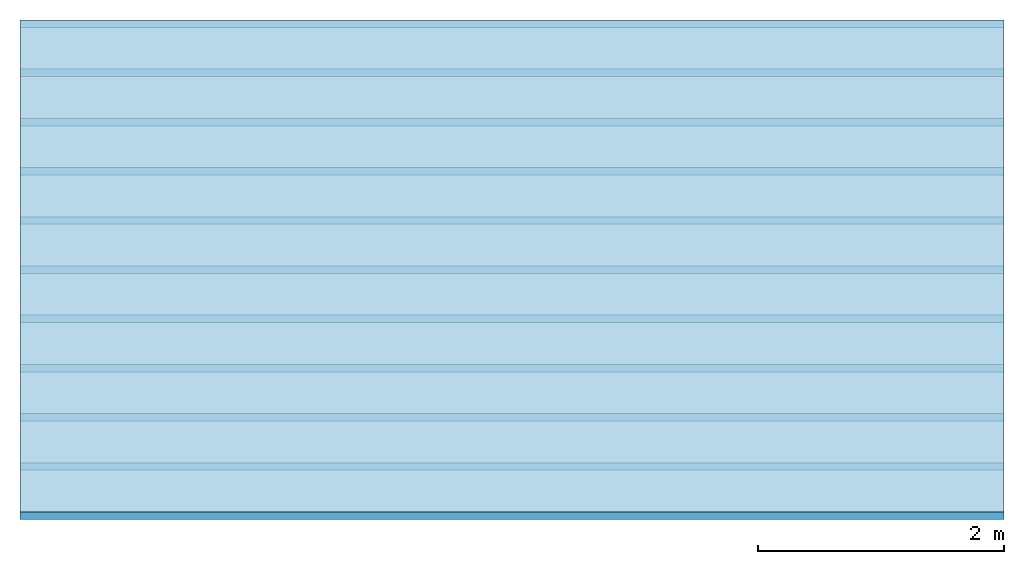
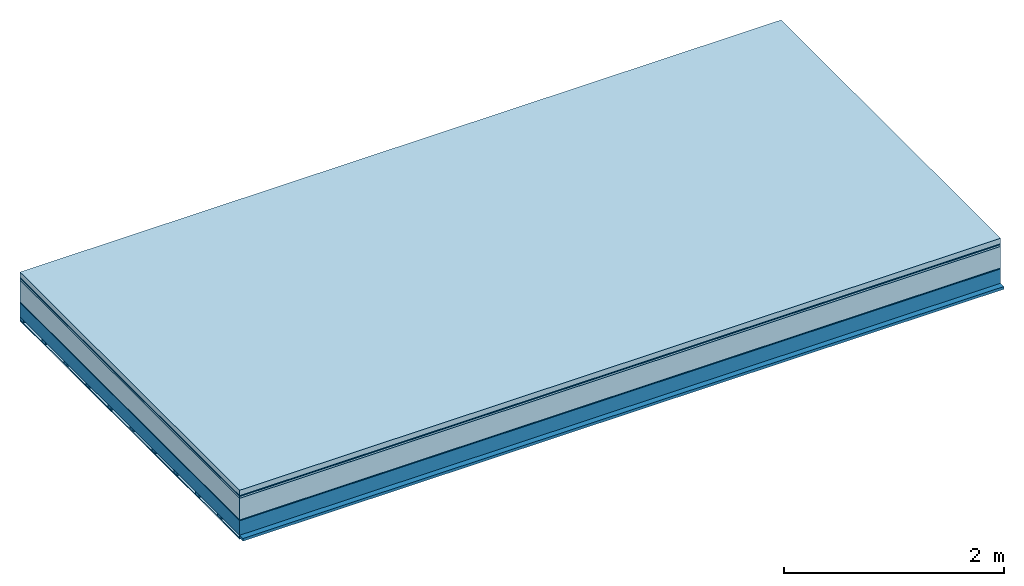
# One storey: 7 plates, 2 members, 1 element without a shape of its own.
"""IFC4 building model written with IfcOpenShell, lengths in metres."""

from ifc_helpers import new_model, si_unit, derived_unit, direction, frame, frame_2d, origin, origin_with_axes, place, context, project, spatial, rectangle, extrude, material, layer, layer_set, type_object, element, aggregate, save


model = new_model("IFC4")

# Units and contexts
plan_context = context("Plan", 3, precision=1e-05, world=origin(), true_north=direction((0.0, 1.0)))
model_context = context("Model", 3, precision=1e-05, world=origin(), true_north=direction((0.0, 1.0)))
ifc_project = project(units=[si_unit("LENGTHUNIT", "METRE"), derived_unit("SOUNDPRESSUREUNIT", [(si_unit("PRESSUREUNIT", "PASCAL", prefix="MICRO"), 0)]), si_unit("ENERGYUNIT", "JOULE", prefix="MEGA"), si_unit("MASSUNIT", "GRAM", prefix="KILO"), derived_unit("THERMALTRANSMITTANCEUNIT", [(si_unit("POWERUNIT", "WATT"), 1), (si_unit("AREAUNIT", "SQUARE_METRE"), -1), (si_unit("THERMODYNAMICTEMPERATUREUNIT", "KELVIN"), -1)]), derived_unit("AREADENSITYUNIT", [(si_unit("MASSUNIT", "GRAM", prefix="KILO"), 1), (si_unit("AREAUNIT", "SQUARE_METRE"), -1)]), derived_unit("USERDEFINED", [(si_unit("ENERGYUNIT", "JOULE", prefix="MEGA"), 1), (si_unit("AREAUNIT", "SQUARE_METRE"), -1)])], contexts=[plan_context, model_context])

# Site, building, storey
site = spatial("IfcSite", under=ifc_project)
building_placement = place(None, origin())
building = spatial("IfcBuilding", under=site, at=building_placement)
storey_placement = place(building_placement, origin())
storey = spatial("IfcBuildingStorey", under=building, at=storey_placement)

# Slab, members, plates
ifc_material_1 = material(Name="clay", Category="02.004")
ifc_layer_1 = layer(ifc_material_1, 0.06, Name="Use and protection layer 2")
ifc_material_2 = material(Name="Protective layer", Category="09.007")
ifc_layer_2 = layer(ifc_material_2, 0.01, Name="Use and protection layer 1")
ifc_material_3 = material(Name="Bituminous", Category="09.003")
ifc_layer_3 = layer(ifc_material_3, 0.02, Name="Seal")
ifc_material_4 = material(Name="Mineral wool", Category="10.008")
ifc_layer_4 = layer(ifc_material_4, 0.24, Name="Exterior insulation layer 1")
ifc_material_5 = material(Name="Vapor-permeable barrier", Category="09.006")
ifc_layer_5 = layer(ifc_material_5, 0.01, Name="layer / temporary roof")
ifc_material_6 = material(Name="no composite action")
ifc_layer_6 = layer(ifc_material_6, 0.0, Name="Bond")
ifc_layer_7 = layer(None, 0.16, Name="Support")
ifc_material_7 = material(Name="of the art")
ifc_layer_8 = layer(ifc_material_7, 0.0, Name="Bond")
ifc_layer_9 = layer(None, 0.03, Name="Battens / profiles")
ifc_material_8 = material(Name="Plasterboard type A", Category="03.008")
ifc_layer_10 = layer(ifc_material_8, 0.0125, Name="Covering below 1st layer")
ifc_material_9 = material(Category="04.001")
ifc_layer_11 = layer(ifc_material_9, 0.003, Name="Surface below")
ifc_layer_set = layer_set([ifc_layer_1, ifc_layer_2, ifc_layer_3, ifc_layer_4, ifc_layer_5, ifc_layer_6, ifc_layer_7, ifc_layer_8, ifc_layer_9, ifc_layer_10, ifc_layer_11])
slab_type = type_object("IfcSlabType", Name="F0076", PredefinedType="NOTDEFINED", material=ifc_layer_set)
slab_placement = place(None, frame((0.0, 0.0, 0.0), z_axis=(0.0, 0.0, -1.0), x_axis=(1.0, 0.0, 0.0)))
slab = element("IfcSlab", 1, at=slab_placement, inside=storey, type_object=slab_type, material=ifc_layer_set, Name="Slab #1")
ifc_material_10 = material(Name="Solid timber panel")
member_1_placement = place(slab_placement, origin())
member_1 = element("IfcMember", 2, at=member_1_placement, material=ifc_material_10, Name="Support", context=plan_context, shape_type="SweptSolid", body=[
    extrude(rectangle(XDim=1.0, YDim=0.16, at=frame_2d((0.5, 0.08), x_axis=(1.0, 0.0))), frame((0.0, 4.0, 0.34), z_axis=(0.0, -1.0, 0.0), x_axis=(1.0, 0.0, 0.0)), (0.0, 0.0, 1.0), 4.0),
    extrude(rectangle(XDim=1.0, YDim=0.16, at=frame_2d((0.5, 0.08), x_axis=(1.0, 0.0))), frame((1.0, 4.0, 0.34), z_axis=(0.0, -1.0, 0.0), x_axis=(1.0, 0.0, 0.0)), (0.0, 0.0, 1.0), 4.0),
    extrude(rectangle(XDim=1.0, YDim=0.16, at=frame_2d((0.5, 0.08), x_axis=(1.0, 0.0))), frame((2.0, 4.0, 0.34), z_axis=(0.0, -1.0, 0.0), x_axis=(1.0, 0.0, 0.0)), (0.0, 0.0, 1.0), 4.0),
    extrude(rectangle(XDim=1.0, YDim=0.16, at=frame_2d((0.5, 0.08), x_axis=(1.0, 0.0))), frame((3.0, 4.0, 0.34), z_axis=(0.0, -1.0, 0.0), x_axis=(1.0, 0.0, 0.0)), (0.0, 0.0, 1.0), 4.0),
    extrude(rectangle(XDim=1.0, YDim=0.16, at=frame_2d((0.5, 0.08), x_axis=(1.0, 0.0))), frame((4.0, 4.0, 0.34), z_axis=(0.0, -1.0, 0.0), x_axis=(1.0, 0.0, 0.0)), (0.0, 0.0, 1.0), 4.0),
    extrude(rectangle(XDim=1.0, YDim=0.16, at=frame_2d((0.5, 0.08), x_axis=(1.0, 0.0))), frame((5.0, 4.0, 0.34), z_axis=(0.0, -1.0, 0.0), x_axis=(1.0, 0.0, 0.0)), (0.0, 0.0, 1.0), 4.0),
    extrude(rectangle(XDim=1.0, YDim=0.16, at=frame_2d((0.5, 0.08), x_axis=(1.0, 0.0))), frame((6.0, 4.0, 0.34), z_axis=(0.0, -1.0, 0.0), x_axis=(1.0, 0.0, 0.0)), (0.0, 0.0, 1.0), 4.0),
    extrude(rectangle(XDim=1.0, YDim=0.16, at=frame_2d((0.5, 0.08), x_axis=(1.0, 0.0))), frame((7.0, 4.0, 0.34), z_axis=(0.0, -1.0, 0.0), x_axis=(1.0, 0.0, 0.0)), (0.0, 0.0, 1.0), 4.0),
])
ifc_material_11 = material()
member_2_placement = place(slab_placement, origin())
member_2 = element("IfcMember", 3, at=member_2_placement, material=ifc_material_11, Name="Battens / profiles", context=plan_context, shape_type="SweptSolid", body=[
    extrude(rectangle(XDim=0.06, YDim=0.03, at=frame_2d((0.03, 0.015), x_axis=(1.0, 0.0))), frame((0.0, 0.0, 0.5), z_axis=(1.0, 0.0, 0.0), x_axis=(0.0, 1.0, 0.0)), (0.0, 0.0, 1.0), 8.0),
    extrude(rectangle(XDim=0.06, YDim=0.03, at=frame_2d((0.03, 0.015), x_axis=(1.0, 0.0))), frame((0.0, 0.4, 0.5), z_axis=(1.0, 0.0, 0.0), x_axis=(0.0, 1.0, 0.0)), (0.0, 0.0, 1.0), 8.0),
    extrude(rectangle(XDim=0.06, YDim=0.03, at=frame_2d((0.03, 0.015), x_axis=(1.0, 0.0))), frame((0.0, 0.8, 0.5), z_axis=(1.0, 0.0, 0.0), x_axis=(0.0, 1.0, 0.0)), (0.0, 0.0, 1.0), 8.0),
    extrude(rectangle(XDim=0.06, YDim=0.03, at=frame_2d((0.03, 0.015), x_axis=(1.0, 0.0))), frame((0.0, 1.2, 0.5), z_axis=(1.0, 0.0, 0.0), x_axis=(0.0, 1.0, 0.0)), (0.0, 0.0, 1.0), 8.0),
    extrude(rectangle(XDim=0.06, YDim=0.03, at=frame_2d((0.03, 0.015), x_axis=(1.0, 0.0))), frame((0.0, 1.6, 0.5), z_axis=(1.0, 0.0, 0.0), x_axis=(0.0, 1.0, 0.0)), (0.0, 0.0, 1.0), 8.0),
    extrude(rectangle(XDim=0.06, YDim=0.03, at=frame_2d((0.03, 0.015), x_axis=(1.0, 0.0))), frame((0.0, 2.0, 0.5), z_axis=(1.0, 0.0, 0.0), x_axis=(0.0, 1.0, 0.0)), (0.0, 0.0, 1.0), 8.0),
    extrude(rectangle(XDim=0.06, YDim=0.03, at=frame_2d((0.03, 0.015), x_axis=(1.0, 0.0))), frame((0.0, 2.4, 0.5), z_axis=(1.0, 0.0, 0.0), x_axis=(0.0, 1.0, 0.0)), (0.0, 0.0, 1.0), 8.0),
    extrude(rectangle(XDim=0.06, YDim=0.03, at=frame_2d((0.03, 0.015), x_axis=(1.0, 0.0))), frame((0.0, 2.8, 0.5), z_axis=(1.0, 0.0, 0.0), x_axis=(0.0, 1.0, 0.0)), (0.0, 0.0, 1.0), 8.0),
    extrude(rectangle(XDim=0.06, YDim=0.03, at=frame_2d((0.03, 0.015), x_axis=(1.0, 0.0))), frame((0.0, 3.2, 0.5), z_axis=(1.0, 0.0, 0.0), x_axis=(0.0, 1.0, 0.0)), (0.0, 0.0, 1.0), 8.0),
    extrude(rectangle(XDim=0.06, YDim=0.03, at=frame_2d((0.03, 0.015), x_axis=(1.0, 0.0))), frame((0.0, 3.6, 0.5), z_axis=(1.0, 0.0, 0.0), x_axis=(0.0, 1.0, 0.0)), (0.0, 0.0, 1.0), 8.0),
    extrude(rectangle(XDim=0.06, YDim=0.03, at=frame_2d((0.03, 0.015), x_axis=(1.0, 0.0))), frame((0.0, 4.0, 0.5), z_axis=(1.0, 0.0, 0.0), x_axis=(0.0, 1.0, 0.0)), (0.0, 0.0, 1.0), 8.0),
])
plate_1_placement = place(slab_placement, origin())
plate_1 = element("IfcPlate", 4, at=plate_1_placement, material=ifc_material_1, Name="Use and protection layer 2", context=plan_context, shape_type="SweptSolid", body=[
    extrude(rectangle(XDim=8.0, YDim=4.0, at=frame_2d((4.0, 2.0), x_axis=(1.0, 0.0))), origin_with_axes(), (0.0, 0.0, 1.0), 0.06),
])
plate_2_placement = place(slab_placement, origin())
plate_2 = element("IfcPlate", 5, at=plate_2_placement, material=ifc_material_2, Name="Use and protection layer 1", context=plan_context, shape_type="SweptSolid", body=[
    extrude(rectangle(XDim=8.0, YDim=4.0, at=frame_2d((4.0, 2.0), x_axis=(1.0, 0.0))), frame((0.0, 0.0, 0.06), z_axis=(0.0, 0.0, 1.0), x_axis=(1.0, 0.0, 0.0)), (0.0, 0.0, 1.0), 0.01),
])
plate_3_placement = place(slab_placement, origin())
plate_3 = element("IfcPlate", 6, at=plate_3_placement, material=ifc_material_3, Name="Seal", context=plan_context, shape_type="SweptSolid", body=[
    extrude(rectangle(XDim=8.0, YDim=4.0, at=frame_2d((4.0, 2.0), x_axis=(1.0, 0.0))), frame((0.0, 0.0, 0.07), z_axis=(0.0, 0.0, 1.0), x_axis=(1.0, 0.0, 0.0)), (0.0, 0.0, 1.0), 0.02),
])
plate_4_placement = place(slab_placement, origin())
plate_4 = element("IfcPlate", 7, at=plate_4_placement, material=ifc_material_4, Name="Exterior insulation layer 1", context=plan_context, shape_type="SweptSolid", body=[
    extrude(rectangle(XDim=8.0, YDim=4.0, at=frame_2d((4.0, 2.0), x_axis=(1.0, 0.0))), frame((0.0, 0.0, 0.09), z_axis=(0.0, 0.0, 1.0), x_axis=(1.0, 0.0, 0.0)), (0.0, 0.0, 1.0), 0.24),
])
plate_5_placement = place(slab_placement, origin())
plate_5 = element("IfcPlate", 8, at=plate_5_placement, material=ifc_material_5, Name="layer / temporary roof", context=plan_context, shape_type="SweptSolid", body=[
    extrude(rectangle(XDim=8.0, YDim=4.0, at=frame_2d((4.0, 2.0), x_axis=(1.0, 0.0))), frame((0.0, 0.0, 0.33), z_axis=(0.0, 0.0, 1.0), x_axis=(1.0, 0.0, 0.0)), (0.0, 0.0, 1.0), 0.01),
])
plate_6_placement = place(slab_placement, origin())
plate_6 = element("IfcPlate", 9, at=plate_6_placement, material=ifc_material_8, Name="Covering below 1st layer", context=plan_context, shape_type="SweptSolid", body=[
    extrude(rectangle(XDim=8.0, YDim=4.0, at=frame_2d((4.0, 2.0), x_axis=(1.0, 0.0))), frame((0.0, 0.0, 0.53), z_axis=(0.0, 0.0, 1.0), x_axis=(1.0, 0.0, 0.0)), (0.0, 0.0, 1.0), 0.0125),
])
plate_7_placement = place(slab_placement, origin())
plate_7 = element("IfcPlate", 10, at=plate_7_placement, material=ifc_material_9, Name="Surface below", context=plan_context, shape_type="SweptSolid", body=[
    extrude(rectangle(XDim=8.0, YDim=4.0, at=frame_2d((4.0, 2.0), x_axis=(1.0, 0.0))), frame((0.0, 0.0, 0.5425), z_axis=(0.0, 0.0, 1.0), x_axis=(1.0, 0.0, 0.0)), (0.0, 0.0, 1.0), 0.003),
])
aggregate(slab, [plate_1, plate_2, plate_3, plate_4, plate_5, member_1, member_2, plate_6, plate_7])

save(model, "model.ifc")
